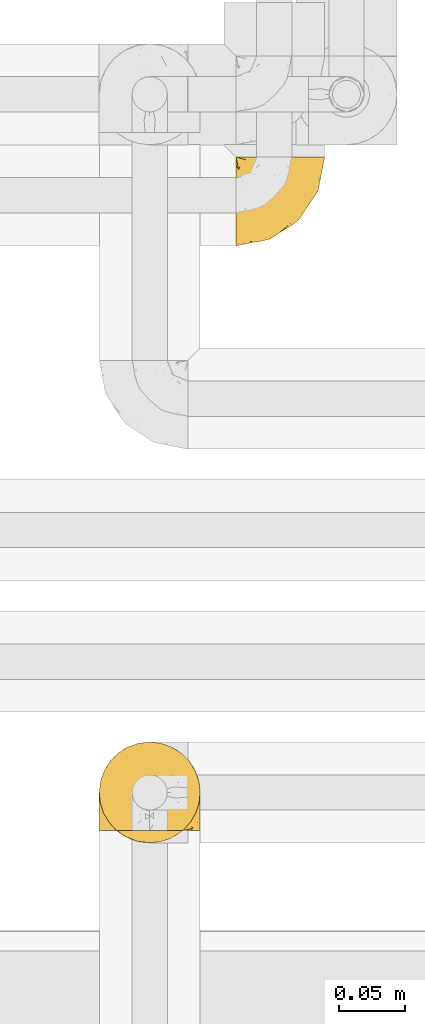
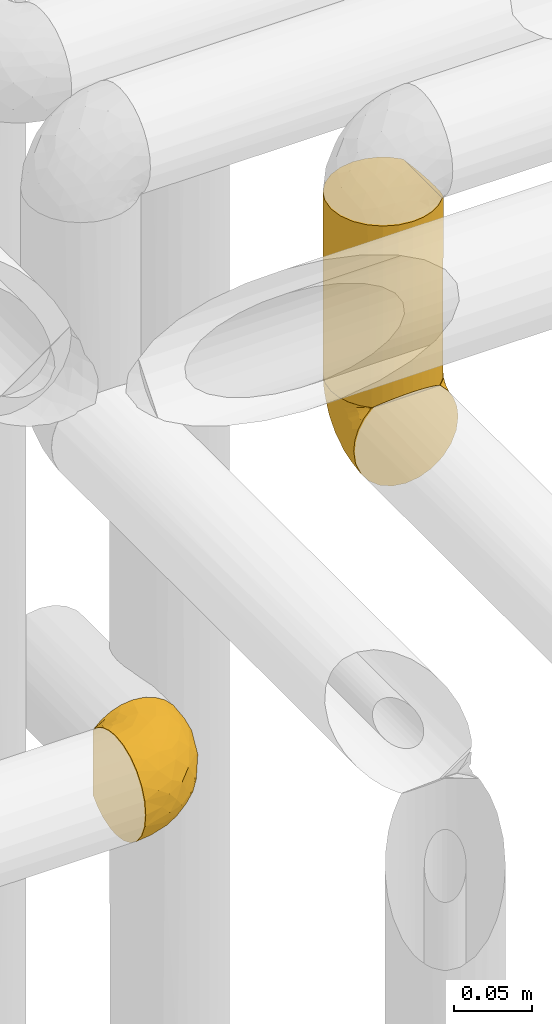
# One storey, part 290 of 827: 3 coverings.
"""IFC2X3 building model written with IfcOpenShell, lengths in millimetres."""

import ifcopenshell
import ifcopenshell.guid

model = None  # the IFC model being written
_history = None  # IfcOwnerHistory: only IFC2X3 demands one
_inside = {}  # id of a spatial element -> (the spatial element, [elements in it])
_under = {}  # id of a project, library or spatial element -> (it, [spatial elements below it])
_declared = {}  # id of a project -> (the project, [libraries it declares])
_typed = {}  # id of a type object -> (the type object, [elements of that type])
_made_of = {}  # id of a material, layer set ... -> (it, [elements and type objects made of it])


def new_model(schema):
    """Start an empty IFC model of exactly this schema.

    Asked for "IFC4X3", IfcOpenShell would pick the latest addendum, in which some entities
    have other attributes; the version numbers below select the first issue.
    IFC2X3 requires an IfcOwnerHistory on every rooted entity: one is made here for all.
    """
    global model, _history
    if schema == "IFC4X3":
        model = ifcopenshell.file(schema_version=(4, 3, 0, 0))
    else:
        model = ifcopenshell.file(schema=schema)
    _inside.clear()
    _under.clear()
    _declared.clear()
    _typed.clear()
    _made_of.clear()
    _history = None
    if model.schema == "IFC2X3":
        org = make("IfcOrganization", Name="unknown")
        user = make(
            "IfcPersonAndOrganization",
            ThePerson=make("IfcPerson", FamilyName="unknown"),
            TheOrganization=org,
        )
        app = make(
            "IfcApplication",
            ApplicationDeveloper=org,
            Version="unknown",
            ApplicationFullName="unknown",
            ApplicationIdentifier="unknown",
        )
        _history = make(
            "IfcOwnerHistory",
            OwningUser=user,
            OwningApplication=app,
            ChangeAction="ADDED",
            CreationDate=0,
        )
    return model


def make(cls, **values):
    """One entity of the class cls with the attributes given. An attribute that is None is left unset."""
    return model.create_entity(
        cls, **{name: value for name, value in values.items() if value is not None}
    )


def entity(cls, *values):
    """Any entity or typed value of the class cls, its attributes in the order of the schema. None: left unset."""
    e = model.create_entity(cls)
    for i, value in enumerate(values):
        if value is not None:
            e[i] = value
    return e


def rooted(cls, **values):
    """An entity with a GlobalId (a new one), such as an element, a storey or a relation."""
    return make(cls, GlobalId=ifcopenshell.guid.new(), OwnerHistory=_history, **values)


def si_unit(unit_type, name, prefix=None):
    """IfcSIUnit, for example si_unit("LENGTHUNIT", "METRE", prefix="MILLI")."""
    return make("IfcSIUnit", UnitType=unit_type, Prefix=prefix, Name=name)


def converted_unit(unit_type, name, factor, base, dimensions=None, offset=None):
    """IfcConversionBasedUnit, such as the inch: factor (a typed value) times the base unit."""
    return make(
        "IfcConversionBasedUnit"
        if offset is None
        else "IfcConversionBasedUnitWithOffset",
        ConversionOffset=offset,
        Dimensions=None
        if dimensions is None
        else entity("IfcDimensionalExponents", *dimensions),
        UnitType=unit_type,
        Name=name,
        ConversionFactor=make(
            "IfcMeasureWithUnit", ValueComponent=factor, UnitComponent=base
        ),
    )


def derived_unit(unit_type, elements):
    """IfcDerivedUnit: a product of units, each with its exponent."""
    return make(
        "IfcDerivedUnit",
        Elements=[
            make("IfcDerivedUnitElement", Unit=unit, Exponent=power)
            for unit, power in elements
        ],
        UnitType=unit_type,
    )


def assignment(units):
    """IfcUnitAssignment: the units of a project."""
    return None if units is None else make("IfcUnitAssignment", Units=units)


def point(xyz):
    """IfcCartesianPoint."""
    return None if xyz is None else make("IfcCartesianPoint", Coordinates=xyz)


def direction(xyz):
    """IfcDirection."""
    return None if xyz is None else make("IfcDirection", DirectionRatios=xyz)


def frame(location, z_axis=None, x_axis=None):
    """IfcAxis2Placement3D, a coordinate frame: its origin and axes. An axis left out is left unset."""
    return make(
        "IfcAxis2Placement3D",
        Location=point(location),
        Axis=direction(z_axis),
        RefDirection=direction(x_axis),
    )


def origin():
    """The frame at (0, 0, 0) with its axes left unset."""
    return frame((0.0, 0.0, 0.0))


def place(relative_to, where):
    """IfcLocalPlacement: puts the frame where relative to a parent placement (None: the world)."""
    return make(
        "IfcLocalPlacement", PlacementRelTo=relative_to, RelativePlacement=where
    )


def context(
    kind, dimensions, precision=None, world=None, true_north=None, identifier=None
):
    """IfcGeometricRepresentationContext, for example the 3D "Model" context."""
    return make(
        "IfcGeometricRepresentationContext",
        ContextIdentifier=identifier,
        ContextType=kind,
        CoordinateSpaceDimension=dimensions,
        Precision=precision,
        WorldCoordinateSystem=world,
        TrueNorth=true_north,
    )


def subcontext(parent, identifier, kind, view, scale=None):
    """IfcGeometricRepresentationSubContext, for example "Body" below "Model"."""
    return make(
        "IfcGeometricRepresentationSubContext",
        ContextIdentifier=identifier,
        ContextType=kind,
        ParentContext=parent,
        TargetScale=scale,
        TargetView=view,
    )


def project(units=None, contexts=None):
    """IfcProject with its units and contexts."""
    return rooted(
        "IfcProject",
        Name="project",
        RepresentationContexts=contexts,
        UnitsInContext=assignment(units),
    )


def spatial(cls, under=None, at=None, **own):
    """A site, building, storey or space (cls), placed at a placement, below another one or the project."""
    s = rooted(cls, ObjectPlacement=at, **own)
    if under is not None:
        _under.setdefault(under.id(), (under, []))[1].append(s)
    return s


def faces_of(points, faces, orient=None, outer=None):
    """IfcFace entities. A face is a list of loops; a loop is a list of indices into points, from 0.

    orient and outer hold one flag for each loop. By default every Orientation is true, the
    first loop of a face is its IfcFaceOuterBound and the others are IfcFaceBound.
    """
    made = []
    for i, loops in enumerate(faces):
        bounds = []
        for j, loop in enumerate(loops):
            is_outer = j == 0 if outer is None else outer[i][j]
            bounds.append(
                make(
                    "IfcFaceOuterBound" if is_outer else "IfcFaceBound",
                    Bound=make("IfcPolyLoop", Polygon=[points[k] for k in loop]),
                    Orientation=True if orient is None else orient[i][j],
                )
            )
        made.append(make("IfcFace", Bounds=bounds))
    return made


def faceted_brep(points, faces, orient=None, outer=None, voids=None):
    """IfcFacetedBrep: a solid bounded by flat faces; with voids (closed shells), ...WithVoids."""
    shared = [point(p) for p in points]
    hull = make("IfcClosedShell", CfsFaces=faces_of(shared, faces, orient, outer))
    if voids is None:
        return make("IfcFacetedBrep", Outer=hull)
    return make(
        "IfcFacetedBrepWithVoids",
        Outer=hull,
        Voids=[
            make(cls, CfsFaces=faces_of(shared, fs, o, b)) for cls, fs, o, b in voids
        ],
    )


def shape(context_of_items, identifier, shape_type, items):
    """IfcShapeRepresentation: the items that make up one representation, for example the "Body"."""
    return make(
        "IfcShapeRepresentation",
        ContextOfItems=context_of_items,
        RepresentationIdentifier=identifier,
        RepresentationType=shape_type,
        Items=items,
    )


def made_of(thing, what):
    """Note that an element or type object is made of a material, layer set ...; save() writes the relation."""
    if what is not None:
        _made_of.setdefault(what.id(), (what, []))[1].append(thing)
    return thing


def element(
    cls,
    number,
    at=None,
    inside=None,
    cuts=None,
    type_object=None,
    material=None,
    context=None,
    identifier="Body",
    shape_type=None,
    held_by="IfcProductDefinitionShape",
    body=None,
    shapes=None,
    **own,
):
    """One element of the class cls, such as IfcWall. Its Tag is "e" and its number.

    at: its placement. inside: the storey or other place that contains it. cuts: it is an
    opening in that element (IfcRelVoidsElement). A single representation is given by context,
    identifier, shape_type and body (its items); several are given by shapes. held_by: the class
    of the entity that holds the representations. save() writes the other relations.
    """
    e = rooted(cls, Tag="e%d" % number, ObjectPlacement=at, **own)
    if body is not None:
        shapes = [shape(context, identifier, shape_type, body)]
    if shapes is not None:
        e.Representation = make(held_by, Representations=shapes)
    if inside is not None:
        _inside.setdefault(inside.id(), (inside, []))[1].append(e)
    if cuts is not None:
        rooted(
            "IfcRelVoidsElement", RelatingBuildingElement=cuts, RelatedOpeningElement=e
        )
    if type_object is not None:
        _typed.setdefault(type_object.id(), (type_object, []))[1].append(e)
    return made_of(e, material)


def aggregate(whole, parts):
    """IfcRelAggregates: a whole, such as a stair, and the parts it consists of."""
    return rooted("IfcRelAggregates", RelatingObject=whole, RelatedObjects=parts)


def save(model, path):
    """Write the relations noted so far, then the file.

    IfcRelAggregates (storeys below a building ...), IfcRelContainedInSpatialStructure (elements
    in a storey), IfcRelDefinesByType, IfcRelAssociatesMaterial and IfcRelDeclares: one each for
    every whole, place, type object, material and project.
    """
    for whole, parts in _under.values():
        aggregate(whole, parts)
    for where, things in _inside.values():
        rooted(
            "IfcRelContainedInSpatialStructure",
            RelatedElements=things,
            RelatingStructure=where,
        )
    for kind, things in _typed.values():
        rooted("IfcRelDefinesByType", RelatedObjects=things, RelatingType=kind)
    for what, things in _made_of.values():
        rooted("IfcRelAssociatesMaterial", RelatedObjects=things, RelatingMaterial=what)
    for by, libraries in _declared.values():
        rooted("IfcRelDeclares", RelatingContext=by, RelatedDefinitions=libraries)
    model.write(path)


model = new_model("IFC2X3")

# Units and contexts
model_context = context("Model", 3, precision=0.01, world=origin(), true_north=direction((6.12303176911189e-17, 1.0)))
body_context = subcontext(model_context, "Body", "Model", "MODEL_VIEW")
ifc_project = project(units=[si_unit("LENGTHUNIT", "METRE", prefix="MILLI"), si_unit("AREAUNIT", "SQUARE_METRE"), si_unit("VOLUMEUNIT", "CUBIC_METRE"), converted_unit("PLANEANGLEUNIT", "DEGREE", entity("IfcRatioMeasure", 0.0174532925199433), si_unit("PLANEANGLEUNIT", "RADIAN"), dimensions=[0, 0, 0, 0, 0, 0, 0]), si_unit("MASSUNIT", "GRAM", prefix="KILO"), derived_unit("MASSDENSITYUNIT", [(si_unit("MASSUNIT", "GRAM", prefix="KILO"), 1), (si_unit("LENGTHUNIT", "METRE"), -3)]), derived_unit("MOMENTOFINERTIAUNIT", [(si_unit("LENGTHUNIT", "METRE"), 4)]), si_unit("TIMEUNIT", "SECOND"), si_unit("FREQUENCYUNIT", "HERTZ"), si_unit("THERMODYNAMICTEMPERATUREUNIT", "DEGREE_CELSIUS"), derived_unit("THERMALTRANSMITTANCEUNIT", [(si_unit("MASSUNIT", "GRAM", prefix="KILO"), 1), (si_unit("THERMODYNAMICTEMPERATUREUNIT", "KELVIN"), -1), (si_unit("TIMEUNIT", "SECOND"), -3)]), derived_unit("VOLUMETRICFLOWRATEUNIT", [(si_unit("LENGTHUNIT", "METRE"), 3), (si_unit("TIMEUNIT", "SECOND"), -1)]), derived_unit("MASSFLOWRATEUNIT", [(si_unit("MASSUNIT", "GRAM", prefix="KILO"), 1), (si_unit("TIMEUNIT", "SECOND"), -1)]), derived_unit("ROTATIONALFREQUENCYUNIT", [(si_unit("TIMEUNIT", "SECOND"), -1)]), si_unit("ELECTRICCURRENTUNIT", "AMPERE"), si_unit("ELECTRICVOLTAGEUNIT", "VOLT"), si_unit("POWERUNIT", "WATT"), si_unit("FORCEUNIT", "NEWTON", prefix="KILO"), si_unit("ILLUMINANCEUNIT", "LUX"), si_unit("LUMINOUSFLUXUNIT", "LUMEN"), si_unit("LUMINOUSINTENSITYUNIT", "CANDELA"), derived_unit("USERDEFINED", [(si_unit("MASSUNIT", "GRAM", prefix="KILO"), -1), (si_unit("LENGTHUNIT", "METRE"), -2), (si_unit("TIMEUNIT", "SECOND"), 3), (si_unit("LUMINOUSFLUXUNIT", "LUMEN"), 1)]), derived_unit("LINEARVELOCITYUNIT", [(si_unit("LENGTHUNIT", "METRE"), 1), (si_unit("TIMEUNIT", "SECOND"), -1)]), si_unit("PRESSUREUNIT", "PASCAL"), derived_unit("USERDEFINED", [(si_unit("LENGTHUNIT", "METRE"), -2), (si_unit("MASSUNIT", "GRAM", prefix="KILO"), 1), (si_unit("TIMEUNIT", "SECOND"), -2)]), derived_unit("LINEARFORCEUNIT", [(si_unit("MASSUNIT", "GRAM", prefix="KILO"), 1), (si_unit("LENGTHUNIT", "METRE"), 1), (si_unit("TIMEUNIT", "SECOND"), -2), (si_unit("LENGTHUNIT", "METRE"), -1)]), derived_unit("PLANARFORCEUNIT", [(si_unit("MASSUNIT", "GRAM", prefix="KILO"), 1), (si_unit("LENGTHUNIT", "METRE"), 1), (si_unit("TIMEUNIT", "SECOND"), -2), (si_unit("LENGTHUNIT", "METRE"), -2)])], contexts=[model_context])

# Site, building, storey
site_placement = place(None, origin())
site = spatial("IfcSite", under=ifc_project, at=site_placement, CompositionType="ELEMENT")
building_placement = place(site_placement, origin())
building = spatial("IfcBuilding", under=site, at=building_placement, CompositionType="ELEMENT")
storey_placement = place(building_placement, frame((0.0, 0.0, 28200.0)))
storey = spatial("IfcBuildingStorey", under=building, at=storey_placement, Name="08", CompositionType="ELEMENT", Elevation=28200.0)

# Coverings
covering_1_placement = place(storey_placement, frame((35057.15, 15705.01, 2169.95)))
element("IfcCovering", 1, at=covering_1_placement, inside=storey, Name=":ADSK_", ObjectType=":ADSK_", PredefinedType="INSULATION", context=body_context, shape_type="Brep", body=[
    faceted_brep([(47.38, 69.15, 74.68), (54.67, 69.15, 70.1), (60.76, 69.15, 64.01), (65.34, 69.15, 56.72), (68.18, 69.15, 48.6), (69.15, 69.15, 40.05), (68.18, 69.15, 31.49), (65.33, 69.15, 23.36), (60.75, 69.15, 16.07), (54.66, 69.15, 9.98), (47.37, 69.15, 5.4), (39.25, 69.15, 2.56), (30.7, 69.15, 1.6), (22.59, 69.15, 2.46), (14.86, 69.15, 5.01), (7.84, 69.15, 9.13), (1.85, 69.15, 14.62), (1.85, 69.15, 16.82), (1.85, 69.15, 18.56), (1.85, 69.15, 20.52), (1.85, 69.15, 22.49), (1.85, 69.15, 24.46), (1.85, 69.15, 26.42), (1.85, 69.15, 28.39), (1.85, 69.15, 30.36), (1.85, 69.15, 32.55), (1.85, 69.15, 34.75), (1.85, 69.15, 36.94), (1.85, 69.15, 39.13), (1.85, 69.15, 41.33), (1.85, 69.15, 43.52), (1.85, 69.15, 45.72), (1.85, 69.15, 47.91), (1.85, 69.15, 50.11), (1.85, 69.15, 52.3), (1.85, 69.15, 54.49), (1.85, 69.15, 56.69), (1.85, 69.15, 58.88), (1.85, 69.15, 61.08), (1.85, 69.15, 63.27), (1.85, 69.15, 65.47), (7.85, 69.15, 70.97), (14.88, 69.15, 75.09), (22.61, 69.15, 77.64), (30.7, 69.15, 78.5), (39.26, 69.15, 77.53), (1.6, 68.89, 14.62), (1.6, 62.89, 9.12), (1.6, 55.87, 5.0), (1.6, 48.14, 2.46), (1.6, 40.05, 1.6), (1.6, 30.09, 2.91), (1.6, 20.82, 6.75), (1.6, 12.86, 12.86), (1.6, 6.75, 20.82), (1.6, 2.91, 30.09), (1.6, 1.6, 40.05), (1.6, 2.91, 50.0), (1.6, 6.75, 59.27), (1.6, 12.86, 67.23), (1.6, 20.82, 73.34), (1.6, 30.09, 77.19), (1.6, 40.05, 78.5), (1.6, 48.14, 77.63), (1.6, 55.87, 75.09), (1.6, 62.89, 70.97), (1.6, 68.89, 65.47), (1.6, 68.89, 63.27), (1.6, 68.89, 62.29), (1.6, 68.89, 60.7), (1.6, 68.89, 59.11), (1.6, 68.89, 57.52), (1.6, 68.89, 55.93), (1.6, 68.89, 54.34), (1.6, 68.89, 52.76), (1.6, 68.89, 51.17), (1.6, 68.89, 49.58), (1.6, 68.89, 47.99), (1.6, 68.89, 46.4), (1.6, 68.89, 44.81), (1.6, 68.89, 43.22), (1.6, 68.89, 41.63), (1.6, 68.89, 40.05), (1.6, 68.89, 38.46), (1.6, 68.89, 36.87), (1.6, 68.89, 35.28), (1.6, 68.89, 33.69), (1.6, 68.89, 32.1), (1.6, 68.89, 30.51), (1.6, 68.89, 28.92), (1.6, 68.89, 27.33), (1.6, 68.89, 25.37), (1.6, 68.89, 23.4), (1.6, 68.89, 21.21), (1.6, 68.89, 19.01), (1.6, 68.89, 16.82), (1.78, 68.97, 42.32), (1.77, 68.96, 44.02), (1.78, 68.97, 47.13), (1.77, 68.97, 48.74), (1.79, 68.98, 23.57), (1.78, 68.97, 25.13), (1.76, 68.96, 61.34), (1.77, 68.96, 22.02), (1.77, 68.96, 29.72), (1.76, 68.96, 56.73), (1.77, 68.96, 55.14), (1.77, 68.96, 37.66), (1.8, 69.0, 64.12), (1.76, 68.96, 28.13), (1.77, 68.96, 26.62), (1.78, 68.97, 31.46), (1.77, 68.96, 16.16), (1.77, 68.96, 39.16), (1.76, 68.96, 50.37), (1.77, 68.97, 17.69), (1.78, 68.97, 19.17), (1.77, 68.97, 62.78), (1.77, 68.96, 58.35), (1.77, 68.96, 45.53), (1.78, 68.97, 59.91), (1.77, 68.97, 65.47), (1.8, 69.02, 65.47), (1.82, 69.08, 65.47), (1.77, 68.97, 14.62), (1.72, 68.94, 14.62), (1.66, 68.92, 14.62), (1.76, 68.96, 20.59), (1.77, 68.96, 32.99), (1.76, 68.95, 34.48), (1.77, 68.96, 51.91), (1.66, 68.92, 65.47), (1.72, 68.94, 65.47), (1.78, 68.98, 53.48), (1.82, 69.08, 14.62), (1.8, 69.02, 14.62), (1.77, 68.96, 40.77), (1.78, 68.97, 35.97), (3.72, 61.33, 7.84), (7.41, 53.1, 3.53), (6.13, 63.33, 8.32), (21.47, 49.27, 1.6), (19.34, 55.53, 2.19), (26.8, 54.6, 1.6), (8.87, 41.99, 1.6), (9.2, 57.07, 4.57), (12.79, 57.95, 3.96), (14.62, 51.56, 2.28), (7.34, 41.58, 1.6), (5.33, 61.7, 7.69), (17.64, 63.33, 3.53), (7.7, 65.0, 8.32), (9.41, 67.02, 7.84), (28.75, 61.87, 1.6), (16.15, 43.94, 1.6), (14.14, 61.21, 4.34), (29.16, 63.4, 1.6), (57.02, 33.11, 29.63), (64.92, 52.82, 27.34), (64.0, 43.3, 40.05), (11.92, 33.73, 2.39), (19.16, 36.52, 2.43), (28.65, 24.87, 9.07), (24.62, 14.17, 16.64), (15.19, 18.43, 9.54), (18.36, 28.67, 4.52), (9.2, 26.0, 4.52), (46.98, 49.25, 7.49), (50.24, 59.72, 7.49), (56.1, 55.1, 12.85), (28.97, 44.72, 2.35), (54.46, 34.15, 22.66), (21.34, 5.25, 32.9), (18.4, 6.75, 25.33), (66.44, 55.54, 40.05), (12.07, 10.47, 16.64), (45.49, 25.49, 19.99), (50.57, 35.53, 16.37), (36.04, 48.22, 3.26), (42.07, 58.71, 3.75), (62.12, 57.42, 19.58), (37.37, 34.84, 7.5), (29.39, 36.87, 4.04), (53.59, 45.01, 13.94), (58.06, 44.4, 19.58), (49.27, 23.96, 28.21), (29.63, 11.2, 24.75), (33.21, 10.56, 31.42), (40.1, 16.81, 26.2), (44.08, 17.38, 33.36), (49.36, 21.38, 40.05), (56.68, 32.34, 40.05), (15.2, 4.3, 40.05), (35.57, 20.65, 16.14), (41.7, 29.66, 12.85), (46.4, 39.6, 10.47), (41.41, 42.55, 6.49), (27.45, 6.74, 40.05), (38.4, 14.06, 40.05), (12.99, 26.84, 75.57), (21.33, 5.28, 47.37), (42.89, 18.52, 52.91), (57.04, 33.13, 50.46), (56.11, 55.1, 67.23), (62.13, 57.43, 60.5), (21.89, 20.72, 70.55), (16.62, 11.46, 63.45), (32.9, 17.69, 62.61), (46.99, 49.26, 72.6), (50.25, 59.73, 72.6), (42.08, 58.71, 76.34), (49.91, 29.72, 59.34), (15.6, 35.35, 77.76), (16.15, 43.94, 78.5), (8.87, 41.99, 78.5), (29.16, 63.4, 78.5), (13.16, 4.93, 53.16), (10.83, 17.46, 70.55), (33.8, 10.94, 48.88), (25.02, 8.92, 54.76), (64.92, 52.83, 52.74), (32.83, 29.34, 71.93), (20.56, 30.26, 75.79), (58.07, 44.4, 60.5), (21.46, 39.06, 77.86), (28.1, 43.06, 77.64), (26.8, 54.6, 78.5), (21.47, 49.27, 78.5), (51.29, 42.69, 67.23), (36.04, 48.2, 76.82), (28.75, 61.87, 78.5), (8.45, 33.44, 77.8), (41.73, 29.67, 67.23), (39.27, 38.5, 73.2), (33.56, 23.35, 67.66), (27.29, 34.97, 75.99), (7.41, 53.1, 76.57), (3.51, 59.68, 73.21), (4.68, 62.19, 71.93), (5.52, 64.11, 71.07), (8.75, 57.97, 75.09), (12.79, 57.95, 76.13), (17.65, 63.33, 76.57), (13.9, 51.77, 77.69), (9.42, 67.02, 72.26), (7.68, 64.98, 71.77), (19.33, 55.53, 77.9), (14.13, 61.22, 75.75)], [[[0, 1, 2, 3, 4, 5, 6, 7, 8, 9, 10, 11, 12, 13, 14, 15, 16, 17, 18, 19, 20, 21, 22, 23, 24, 25, 26, 27, 28, 29, 30, 31, 32, 33, 34, 35, 36, 37, 38, 39, 40, 41, 42, 43, 44, 45]], [[46, 47, 48, 49, 50, 51, 52, 53, 54, 55, 56, 57, 58, 59, 60, 61, 62, 63, 64, 65, 66, 67, 68, 69, 70, 71, 72, 73, 74, 75, 76, 77, 78, 79, 80, 81, 82, 83, 84, 85, 86, 87, 88, 89, 90, 91, 92, 93, 94, 95]], [[96, 97, 30]], [[98, 77, 99]], [[100, 101, 21]], [[69, 68, 102]], [[20, 19, 103]], [[24, 23, 104]], [[20, 103, 100]], [[72, 105, 106]], [[84, 83, 107]], [[89, 88, 104]], [[108, 67, 66]], [[109, 110, 90]], [[111, 25, 24]], [[112, 17, 16]], [[82, 113, 83]], [[109, 23, 22]], [[114, 76, 75]], [[105, 36, 106]], [[104, 111, 24]], [[18, 115, 116]], [[97, 96, 80]], [[67, 108, 117]], [[105, 71, 118]], [[31, 97, 119]], [[102, 120, 69]], [[108, 121, 122, 123, 40]], [[112, 95, 115]], [[17, 115, 18]], [[94, 116, 115]], [[117, 68, 67]], [[38, 117, 39]], [[112, 124, 125]], [[112, 126, 46]], [[17, 112, 115]], [[70, 120, 118]], [[39, 117, 108]], [[120, 38, 37]], [[120, 37, 118]], [[120, 70, 69]], [[116, 94, 127]], [[128, 86, 129]], [[117, 38, 102]], [[74, 130, 75]], [[99, 33, 32]], [[115, 95, 94]], [[39, 108, 40]], [[108, 66, 131, 132, 121]], [[105, 72, 71]], [[118, 37, 36]], [[71, 70, 118]], [[35, 106, 36]], [[36, 105, 118]], [[35, 133, 106]], [[74, 73, 133]], [[106, 133, 73]], [[99, 114, 33]], [[133, 35, 34]], [[73, 72, 106]], [[95, 112, 46]], [[112, 16, 134, 135, 124]], [[130, 114, 75]], [[99, 76, 114]], [[114, 130, 33]], [[34, 33, 130]], [[78, 77, 98]], [[98, 119, 78]], [[130, 133, 34]], [[133, 130, 74]], [[79, 97, 80]], [[98, 99, 32]], [[98, 32, 31]], [[77, 76, 99]], [[97, 79, 119]], [[136, 96, 29]], [[30, 97, 31]], [[136, 29, 28]], [[81, 80, 96]], [[29, 96, 30]], [[31, 119, 98]], [[119, 79, 78]], [[96, 136, 81]], [[82, 81, 136]], [[113, 107, 83]], [[84, 107, 137]], [[107, 27, 137]], [[113, 28, 107]], [[27, 107, 28]], [[85, 84, 137]], [[137, 27, 26]], [[113, 136, 28]], [[136, 113, 82]], [[109, 89, 104]], [[86, 85, 129]], [[89, 109, 90]], [[111, 87, 128]], [[26, 129, 137]], [[88, 111, 104]], [[25, 111, 128]], [[22, 110, 109]], [[23, 109, 104]], [[110, 91, 90]], [[100, 92, 101]], [[110, 22, 101]], [[91, 110, 101]], [[116, 19, 18]], [[111, 88, 87]], [[127, 103, 19]], [[25, 128, 26]], [[86, 128, 87]], [[128, 129, 26]], [[137, 129, 85]], [[120, 102, 38]], [[117, 102, 68]], [[91, 101, 92]], [[21, 101, 22]], [[93, 92, 103]], [[100, 21, 20]], [[100, 103, 92]], [[127, 93, 103]], [[93, 127, 94]], [[116, 127, 19]], [[126, 138, 47]], [[48, 138, 139]], [[140, 125, 124]], [[141, 142, 143]], [[144, 49, 139]], [[145, 140, 146]], [[48, 139, 49]], [[139, 145, 147]], [[49, 144, 148, 50]], [[126, 125, 149]], [[14, 13, 150]], [[151, 146, 140]], [[149, 140, 145]], [[152, 151, 135]], [[152, 14, 150]], [[16, 15, 134]], [[13, 153, 150]], [[124, 151, 140]], [[141, 147, 142]], [[14, 152, 15]], [[15, 152, 134]], [[47, 46, 126]], [[139, 154, 144]], [[138, 48, 47]], [[125, 140, 149]], [[135, 134, 152]], [[146, 155, 142]], [[145, 146, 147]], [[149, 139, 138]], [[147, 141, 154]], [[147, 146, 142]], [[139, 147, 154]], [[139, 149, 145]], [[149, 138, 126]], [[155, 146, 151]], [[150, 143, 142]], [[152, 155, 151]], [[150, 142, 155]], [[13, 12, 156, 153]], [[153, 143, 150]], [[152, 150, 155]], [[151, 124, 135]], [[157, 158, 159]], [[160, 154, 161]], [[162, 163, 164]], [[165, 166, 160]], [[167, 168, 169]], [[141, 170, 161]], [[156, 12, 11]], [[158, 157, 171]], [[172, 55, 173]], [[158, 6, 174]], [[175, 54, 53]], [[52, 166, 164]], [[52, 164, 53]], [[54, 175, 173]], [[166, 52, 51]], [[176, 177, 171]], [[178, 143, 179]], [[156, 11, 179]], [[8, 7, 180]], [[169, 9, 8]], [[179, 143, 153, 156]], [[179, 11, 10]], [[168, 179, 10]], [[181, 162, 182]], [[179, 167, 178]], [[183, 184, 177]], [[183, 169, 184]], [[176, 171, 185]], [[172, 186, 187]], [[158, 7, 6]], [[159, 158, 174]], [[184, 180, 158]], [[54, 173, 55]], [[180, 169, 8]], [[188, 189, 187]], [[9, 168, 10]], [[186, 188, 187]], [[190, 157, 159, 191]], [[55, 172, 192]], [[176, 193, 194]], [[161, 170, 182]], [[162, 164, 165]], [[175, 164, 163]], [[51, 50, 148]], [[167, 195, 196]], [[178, 182, 170]], [[6, 5, 174]], [[158, 180, 7]], [[169, 180, 184]], [[169, 168, 9]], [[179, 168, 167]], [[182, 162, 165]], [[162, 194, 193]], [[161, 165, 160]], [[195, 181, 196]], [[192, 172, 197]], [[192, 56, 55]], [[189, 190, 198]], [[198, 197, 187]], [[172, 187, 197]], [[185, 189, 188]], [[198, 187, 189]], [[186, 172, 173]], [[173, 163, 186]], [[193, 186, 163]], [[176, 185, 188]], [[185, 157, 190]], [[188, 186, 193]], [[177, 176, 194]], [[188, 193, 176]], [[162, 193, 163]], [[195, 177, 194]], [[171, 177, 184]], [[181, 195, 194]], [[183, 167, 169]], [[162, 181, 194]], [[196, 182, 178]], [[158, 171, 184]], [[171, 157, 185]], [[177, 195, 183]], [[167, 183, 195]], [[182, 196, 181]], [[178, 170, 143]], [[178, 167, 196]], [[164, 175, 53]], [[173, 175, 163]], [[160, 51, 148]], [[164, 166, 165]], [[51, 160, 166]], [[160, 148, 144, 154]], [[141, 161, 154]], [[182, 165, 161]], [[190, 189, 185]], [[143, 170, 141]], [[60, 199, 61]], [[197, 200, 192]], [[201, 190, 202]], [[200, 57, 192]], [[203, 204, 2]], [[205, 206, 207]], [[208, 209, 210]], [[211, 207, 201]], [[212, 213, 214]], [[45, 215, 210]], [[216, 206, 58]], [[45, 44, 215]], [[59, 217, 60]], [[60, 217, 199]], [[0, 45, 210]], [[218, 201, 219]], [[202, 159, 220]], [[205, 221, 222]], [[223, 204, 203]], [[1, 203, 2]], [[57, 200, 216]], [[220, 3, 204]], [[220, 174, 4]], [[1, 0, 209]], [[212, 224, 213]], [[225, 226, 227]], [[228, 223, 203]], [[208, 210, 229]], [[210, 226, 229]], [[3, 220, 4]], [[58, 206, 59]], [[209, 203, 1]], [[202, 220, 223]], [[228, 203, 208]], [[202, 211, 201]], [[3, 2, 204]], [[202, 190, 191, 159]], [[210, 215, 230, 226]], [[199, 212, 231]], [[232, 233, 221]], [[233, 208, 229]], [[207, 206, 219]], [[217, 206, 205]], [[227, 224, 225]], [[233, 232, 228]], [[201, 207, 219]], [[234, 232, 221]], [[218, 219, 200]], [[202, 223, 211]], [[174, 220, 159]], [[174, 5, 4]], [[61, 231, 62]], [[220, 204, 223]], [[210, 209, 0]], [[203, 209, 208]], [[225, 233, 229]], [[224, 227, 213]], [[221, 233, 235]], [[57, 56, 192]], [[198, 218, 197]], [[200, 219, 216]], [[201, 198, 190]], [[197, 218, 200]], [[198, 201, 218]], [[206, 216, 219]], [[58, 57, 216]], [[231, 212, 214]], [[222, 212, 199]], [[228, 211, 223]], [[207, 211, 232]], [[62, 231, 214]], [[199, 231, 61]], [[233, 228, 208]], [[211, 228, 232]], [[222, 221, 235]], [[234, 205, 207]], [[206, 217, 59]], [[199, 217, 205]], [[205, 222, 199]], [[224, 222, 235]], [[222, 224, 212]], [[224, 235, 225]], [[233, 225, 235]], [[226, 225, 229]], [[205, 234, 221]], [[207, 232, 234]], [[63, 214, 236]], [[214, 213, 236]], [[214, 63, 62]], [[237, 236, 238]], [[238, 132, 131]], [[236, 237, 64]], [[239, 240, 241]], [[63, 236, 64]], [[131, 66, 65]], [[237, 131, 65]], [[242, 230, 43]], [[237, 65, 64]], [[239, 121, 132]], [[42, 242, 43]], [[241, 240, 243]], [[41, 123, 244]], [[43, 230, 215, 44]], [[244, 122, 245]], [[227, 246, 243]], [[241, 247, 245]], [[121, 239, 245]], [[41, 40, 123]], [[132, 238, 239]], [[244, 42, 41]], [[131, 237, 238]], [[240, 239, 238]], [[245, 239, 241]], [[247, 241, 246]], [[247, 244, 245]], [[238, 236, 240]], [[243, 236, 213]], [[236, 243, 240]], [[227, 226, 246]], [[243, 213, 227]], [[242, 246, 226]], [[243, 246, 241]], [[246, 242, 247]], [[244, 247, 242]], [[242, 226, 230]], [[42, 244, 242]], [[122, 244, 123]], [[122, 121, 245]], [[112, 125, 126]]]),
])
covering_2_placement = place(storey_placement, frame((34952.89, 15250.0, 2827.5)))
element("IfcCovering", 2, at=covering_2_placement, inside=storey, Name=":ADSK_", ObjectType=":ADSK_", PredefinedType="INSULATION", context=body_context, shape_type="Brep", body=[
    faceted_brep([(2.48, 31.79, 1.6), (1.6, 40.0, 1.6), (2.9, 49.93, 1.6), (6.74, 59.2, 1.6), (12.84, 67.15, 1.6), (20.8, 73.25, 1.6), (30.06, 77.09, 1.6), (40.0, 78.4, 1.6), (49.93, 77.09, 1.6), (59.2, 73.25, 1.6), (67.15, 67.15, 1.6), (73.25, 59.2, 1.6), (77.09, 49.93, 1.6), (78.4, 40.0, 1.6), (77.51, 31.79, 1.6), (74.9, 23.98, 1.6), (70.68, 16.91, 1.6), (65.05, 10.9, 1.6), (14.94, 10.9, 1.6), (9.31, 16.91, 1.6), (5.09, 23.98, 1.6), (1.6, 40.0, 143.4), (2.9, 30.06, 143.4), (6.74, 20.8, 143.4), (12.84, 12.84, 143.4), (20.8, 6.74, 143.4), (30.06, 2.9, 143.4), (40.0, 1.6, 143.4), (48.2, 2.48, 143.4), (56.01, 5.09, 143.4), (63.08, 9.31, 143.4), (69.1, 14.94, 143.4), (69.1, 65.05, 143.4), (63.08, 70.68, 143.4), (56.01, 74.9, 143.4), (48.2, 77.51, 143.4), (40.0, 78.4, 143.4), (30.06, 77.09, 143.4), (20.8, 73.25, 143.4), (12.84, 67.15, 143.4), (6.74, 59.2, 143.4), (2.9, 49.93, 143.4), (73.07, 59.51, 139.42), (76.0, 53.36, 136.5), (77.79, 46.78, 134.7), (78.4, 40.0, 134.1), (77.79, 33.21, 134.7), (76.0, 26.63, 136.5), (73.07, 20.48, 139.42), (59.51, 6.92, 5.57), (53.36, 4.0, 8.5), (46.78, 2.2, 10.29), (40.0, 1.6, 10.9), (33.21, 2.2, 10.29), (26.63, 4.0, 8.5), (20.48, 6.92, 5.57)], [[[0, 1, 2, 3, 4, 5, 6, 7, 8, 9, 10, 11, 12, 13, 14, 15, 16, 17, 18, 19, 20]], [[21, 22, 23, 24, 25, 26, 27, 28, 29, 30, 31, 32, 33, 34, 35, 36, 37, 38, 39, 40, 41]], [[36, 35, 7]], [[34, 33, 9]], [[35, 34, 8]], [[8, 7, 35]], [[9, 8, 34]], [[33, 10, 9]], [[33, 32, 10]], [[32, 42, 11]], [[43, 44, 12]], [[42, 43, 11]], [[11, 43, 12]], [[13, 12, 44]], [[45, 13, 44]], [[32, 11, 10]], [[46, 47, 14]], [[48, 31, 16]], [[47, 48, 15]], [[45, 46, 13]], [[14, 13, 46]], [[47, 15, 14]], [[48, 16, 15]], [[31, 17, 16]], [[49, 30, 29]], [[50, 29, 28]], [[51, 28, 27]], [[49, 17, 30]], [[51, 50, 28]], [[52, 51, 27]], [[49, 29, 50]], [[30, 17, 31]], [[53, 52, 27]], [[53, 27, 26]], [[54, 26, 25]], [[54, 53, 26]], [[18, 55, 25]], [[54, 25, 55]], [[25, 24, 18]], [[19, 24, 23]], [[20, 23, 22]], [[0, 22, 21]], [[19, 23, 20]], [[20, 22, 0]], [[21, 1, 0]], [[24, 19, 18]], [[2, 1, 21, 41]], [[3, 2, 41, 40]], [[40, 39, 4, 3]], [[6, 5, 38, 37]], [[7, 6, 37, 36]], [[39, 38, 5, 4]], [[49, 50, 51, 52, 53, 54, 55, 18, 17]], [[31, 48, 47, 46, 45, 44, 43, 42, 32]]]),
])
covering_3_placement = place(storey_placement, frame((34952.84, 15259.3, 2759.95)))
element("IfcCovering", 3, at=covering_3_placement, inside=storey, Name=":ADSK_", ObjectType=":ADSK_", PredefinedType="INSULATION", context=body_context, shape_type="Brep", body=[
    faceted_brep([(74.68, 47.38, 69.15), (70.1, 54.67, 69.15), (64.01, 60.76, 69.15), (56.72, 65.34, 69.15), (48.6, 68.18, 69.15), (40.05, 69.15, 69.15), (31.49, 68.18, 69.15), (23.36, 65.33, 69.15), (16.07, 60.75, 69.15), (9.98, 54.66, 69.15), (5.4, 47.37, 69.15), (2.56, 39.25, 69.15), (1.6, 30.7, 69.15), (2.46, 22.59, 69.15), (5.01, 14.86, 69.15), (9.13, 7.84, 69.15), (14.62, 1.85, 69.15), (16.82, 1.85, 69.15), (18.56, 1.85, 69.15), (20.52, 1.85, 69.15), (22.49, 1.85, 69.15), (24.46, 1.85, 69.15), (26.42, 1.85, 69.15), (28.39, 1.85, 69.15), (30.36, 1.85, 69.15), (32.55, 1.85, 69.15), (34.75, 1.85, 69.15), (36.94, 1.85, 69.15), (39.13, 1.85, 69.15), (41.33, 1.85, 69.15), (43.52, 1.85, 69.15), (45.72, 1.85, 69.15), (47.91, 1.85, 69.15), (50.11, 1.85, 69.15), (52.3, 1.85, 69.15), (54.49, 1.85, 69.15), (56.69, 1.85, 69.15), (58.88, 1.85, 69.15), (61.08, 1.85, 69.15), (63.27, 1.85, 69.15), (65.47, 1.85, 69.15), (70.97, 7.85, 69.15), (75.09, 14.88, 69.15), (77.64, 22.61, 69.15), (78.5, 30.7, 69.15), (77.53, 39.26, 69.15), (14.62, 1.6, 68.89), (9.12, 1.6, 62.89), (5.0, 1.6, 55.87), (2.46, 1.6, 48.14), (1.6, 1.6, 40.05), (2.91, 1.6, 30.09), (6.75, 1.6, 20.82), (12.86, 1.6, 12.86), (20.82, 1.6, 6.75), (30.09, 1.6, 2.91), (40.05, 1.6, 1.6), (50.0, 1.6, 2.91), (59.27, 1.6, 6.75), (67.23, 1.6, 12.86), (73.34, 1.6, 20.82), (77.19, 1.6, 30.09), (78.5, 1.6, 40.05), (77.63, 1.6, 48.14), (75.09, 1.6, 55.87), (70.97, 1.6, 62.89), (65.47, 1.6, 68.89), (63.27, 1.6, 68.89), (62.29, 1.6, 68.89), (60.7, 1.6, 68.89), (59.11, 1.6, 68.89), (57.52, 1.6, 68.89), (55.93, 1.6, 68.89), (54.34, 1.6, 68.89), (52.76, 1.6, 68.89), (51.17, 1.6, 68.89), (49.58, 1.6, 68.89), (47.99, 1.6, 68.89), (46.4, 1.6, 68.89), (44.81, 1.6, 68.89), (43.22, 1.6, 68.89), (41.63, 1.6, 68.89), (40.05, 1.6, 68.89), (38.46, 1.6, 68.89), (36.87, 1.6, 68.89), (35.28, 1.6, 68.89), (33.69, 1.6, 68.89), (32.1, 1.6, 68.89), (30.51, 1.6, 68.89), (28.92, 1.6, 68.89), (27.33, 1.6, 68.89), (25.37, 1.6, 68.89), (23.4, 1.6, 68.89), (21.21, 1.6, 68.89), (19.01, 1.6, 68.89), (16.82, 1.6, 68.89), (42.32, 1.78, 68.97), (44.02, 1.77, 68.96), (47.13, 1.78, 68.97), (48.74, 1.77, 68.97), (23.57, 1.79, 68.98), (25.13, 1.78, 68.97), (61.34, 1.76, 68.96), (22.02, 1.77, 68.96), (29.72, 1.77, 68.96), (56.73, 1.76, 68.96), (55.14, 1.77, 68.96), (37.66, 1.77, 68.96), (64.12, 1.8, 69.0), (28.13, 1.76, 68.96), (26.62, 1.77, 68.96), (31.46, 1.78, 68.97), (16.16, 1.77, 68.96), (39.16, 1.77, 68.96), (50.37, 1.76, 68.96), (17.69, 1.77, 68.97), (19.17, 1.78, 68.97), (62.78, 1.77, 68.97), (58.35, 1.77, 68.96), (45.53, 1.77, 68.96), (59.91, 1.78, 68.97), (65.47, 1.77, 68.97), (65.47, 1.8, 69.02), (65.47, 1.82, 69.08), (14.62, 1.77, 68.97), (14.62, 1.72, 68.94), (14.62, 1.66, 68.92), (20.59, 1.76, 68.96), (32.99, 1.77, 68.96), (34.48, 1.76, 68.95), (51.91, 1.77, 68.96), (65.47, 1.66, 68.92), (65.47, 1.72, 68.94), (53.48, 1.78, 68.98), (14.62, 1.82, 69.08), (14.62, 1.8, 69.02), (40.77, 1.77, 68.96), (35.97, 1.78, 68.97), (7.84, 3.72, 61.33), (3.53, 7.41, 53.1), (8.32, 6.13, 63.33), (1.6, 21.47, 49.27), (2.19, 19.34, 55.53), (1.6, 26.8, 54.6), (1.6, 8.87, 41.99), (4.57, 9.2, 57.07), (3.96, 12.79, 57.95), (2.28, 14.62, 51.56), (1.6, 7.34, 41.58), (7.69, 5.33, 61.7), (3.53, 17.64, 63.33), (8.32, 7.7, 65.0), (7.84, 9.41, 67.02), (1.6, 28.75, 61.87), (1.6, 16.15, 43.94), (4.34, 14.14, 61.21), (1.6, 29.16, 63.4), (29.63, 57.02, 33.11), (27.34, 64.92, 52.82), (40.05, 64.0, 43.3), (2.39, 11.92, 33.73), (2.43, 19.16, 36.52), (9.07, 28.65, 24.87), (16.64, 24.62, 14.17), (9.54, 15.19, 18.43), (4.52, 18.36, 28.67), (4.52, 9.2, 26.0), (7.49, 46.98, 49.25), (7.49, 50.24, 59.72), (12.85, 56.1, 55.1), (2.35, 28.97, 44.72), (22.66, 54.46, 34.15), (32.9, 21.34, 5.25), (25.33, 18.4, 6.75), (40.05, 66.44, 55.54), (16.64, 12.07, 10.47), (19.99, 45.49, 25.49), (16.37, 50.57, 35.53), (3.26, 36.04, 48.22), (3.75, 42.07, 58.71), (19.58, 62.12, 57.42), (7.5, 37.37, 34.84), (4.04, 29.39, 36.87), (13.94, 53.59, 45.01), (19.58, 58.06, 44.4), (28.21, 49.27, 23.96), (24.75, 29.63, 11.2), (31.42, 33.21, 10.56), (26.2, 40.1, 16.81), (33.36, 44.08, 17.38), (40.05, 49.36, 21.38), (40.05, 56.68, 32.34), (40.05, 15.2, 4.3), (16.14, 35.57, 20.65), (12.85, 41.7, 29.66), (10.47, 46.4, 39.6), (6.49, 41.41, 42.55), (40.05, 27.45, 6.74), (40.05, 38.4, 14.06), (75.57, 12.99, 26.84), (47.37, 21.33, 5.28), (52.91, 42.89, 18.52), (50.46, 57.04, 33.13), (67.23, 56.11, 55.1), (60.5, 62.13, 57.43), (70.55, 21.89, 20.72), (63.45, 16.62, 11.46), (62.61, 32.9, 17.69), (72.6, 46.99, 49.26), (72.6, 50.25, 59.73), (76.34, 42.08, 58.71), (59.34, 49.91, 29.72), (77.76, 15.6, 35.35), (78.5, 16.15, 43.94), (78.5, 8.87, 41.99), (78.5, 29.16, 63.4), (53.16, 13.16, 4.93), (70.55, 10.83, 17.46), (48.88, 33.8, 10.94), (54.76, 25.02, 8.92), (52.74, 64.92, 52.83), (71.93, 32.83, 29.34), (75.79, 20.56, 30.26), (60.5, 58.07, 44.4), (77.86, 21.46, 39.06), (77.64, 28.1, 43.06), (78.5, 26.8, 54.6), (78.5, 21.47, 49.27), (67.23, 51.29, 42.69), (76.82, 36.04, 48.2), (78.5, 28.75, 61.87), (77.8, 8.45, 33.44), (67.23, 41.73, 29.67), (73.2, 39.27, 38.5), (67.66, 33.56, 23.35), (75.99, 27.29, 34.97), (76.57, 7.41, 53.1), (73.21, 3.51, 59.68), (71.93, 4.68, 62.19), (71.07, 5.52, 64.11), (75.09, 8.75, 57.97), (76.13, 12.79, 57.95), (76.57, 17.65, 63.33), (77.69, 13.9, 51.77), (72.26, 9.42, 67.02), (71.77, 7.68, 64.98), (77.9, 19.33, 55.53), (75.75, 14.13, 61.22)], [[[0, 1, 2, 3, 4, 5, 6, 7, 8, 9, 10, 11, 12, 13, 14, 15, 16, 17, 18, 19, 20, 21, 22, 23, 24, 25, 26, 27, 28, 29, 30, 31, 32, 33, 34, 35, 36, 37, 38, 39, 40, 41, 42, 43, 44, 45]], [[46, 47, 48, 49, 50, 51, 52, 53, 54, 55, 56, 57, 58, 59, 60, 61, 62, 63, 64, 65, 66, 67, 68, 69, 70, 71, 72, 73, 74, 75, 76, 77, 78, 79, 80, 81, 82, 83, 84, 85, 86, 87, 88, 89, 90, 91, 92, 93, 94, 95]], [[96, 97, 30]], [[98, 77, 99]], [[100, 101, 21]], [[69, 68, 102]], [[20, 19, 103]], [[24, 23, 104]], [[20, 103, 100]], [[72, 105, 106]], [[84, 83, 107]], [[89, 88, 104]], [[108, 67, 66]], [[109, 110, 90]], [[111, 25, 24]], [[112, 17, 16]], [[82, 113, 83]], [[109, 23, 22]], [[114, 76, 75]], [[105, 36, 106]], [[104, 111, 24]], [[18, 115, 116]], [[97, 96, 80]], [[67, 108, 117]], [[105, 71, 118]], [[31, 97, 119]], [[102, 120, 69]], [[108, 121, 122, 123, 40]], [[112, 95, 115]], [[17, 115, 18]], [[94, 116, 115]], [[117, 68, 67]], [[38, 117, 39]], [[112, 124, 125, 126, 46]], [[17, 112, 115]], [[70, 120, 118]], [[39, 117, 108]], [[120, 38, 37]], [[120, 37, 118]], [[120, 70, 69]], [[116, 94, 127]], [[128, 86, 129]], [[117, 38, 102]], [[74, 130, 75]], [[99, 33, 32]], [[115, 95, 94]], [[39, 108, 40]], [[108, 66, 131, 132, 121]], [[105, 72, 71]], [[118, 37, 36]], [[71, 70, 118]], [[35, 106, 36]], [[36, 105, 118]], [[35, 133, 106]], [[74, 73, 133]], [[106, 133, 73]], [[99, 114, 33]], [[133, 35, 34]], [[73, 72, 106]], [[95, 112, 46]], [[112, 16, 134, 135, 124]], [[130, 114, 75]], [[99, 76, 114]], [[114, 130, 33]], [[34, 33, 130]], [[78, 77, 98]], [[98, 119, 78]], [[130, 133, 34]], [[133, 130, 74]], [[79, 97, 80]], [[98, 99, 32]], [[98, 32, 31]], [[77, 76, 99]], [[97, 79, 119]], [[136, 96, 29]], [[30, 97, 31]], [[136, 29, 28]], [[81, 80, 96]], [[29, 96, 30]], [[31, 119, 98]], [[119, 79, 78]], [[96, 136, 81]], [[82, 81, 136]], [[113, 107, 83]], [[84, 107, 137]], [[107, 27, 137]], [[113, 28, 107]], [[27, 107, 28]], [[85, 84, 137]], [[137, 27, 26]], [[113, 136, 28]], [[136, 113, 82]], [[109, 89, 104]], [[86, 85, 129]], [[89, 109, 90]], [[111, 87, 128]], [[26, 129, 137]], [[88, 111, 104]], [[25, 111, 128]], [[22, 110, 109]], [[23, 109, 104]], [[110, 91, 90]], [[100, 92, 101]], [[110, 22, 101]], [[91, 110, 101]], [[116, 19, 18]], [[111, 88, 87]], [[127, 103, 19]], [[25, 128, 26]], [[86, 128, 87]], [[128, 129, 26]], [[137, 129, 85]], [[120, 102, 38]], [[117, 102, 68]], [[91, 101, 92]], [[21, 101, 22]], [[93, 92, 103]], [[100, 21, 20]], [[100, 103, 92]], [[127, 93, 103]], [[93, 127, 94]], [[116, 127, 19]], [[126, 138, 47]], [[48, 138, 139]], [[140, 125, 124]], [[141, 142, 143]], [[144, 49, 139]], [[145, 140, 146]], [[48, 139, 49]], [[139, 145, 147]], [[49, 144, 148, 50]], [[126, 125, 149]], [[14, 13, 150]], [[151, 146, 140]], [[149, 140, 145]], [[152, 151, 135]], [[152, 14, 150]], [[16, 15, 134]], [[13, 153, 150]], [[124, 151, 140]], [[141, 147, 142]], [[14, 152, 15]], [[15, 152, 134]], [[47, 46, 126]], [[139, 154, 144]], [[138, 48, 47]], [[125, 140, 149]], [[135, 134, 152]], [[146, 155, 142]], [[145, 146, 147]], [[149, 139, 138]], [[147, 141, 154]], [[147, 146, 142]], [[139, 147, 154]], [[139, 149, 145]], [[149, 138, 126]], [[155, 146, 151]], [[150, 143, 142]], [[152, 155, 151]], [[150, 142, 155]], [[13, 12, 156, 153]], [[153, 143, 150]], [[152, 150, 155]], [[151, 124, 135]], [[157, 158, 159]], [[160, 154, 161]], [[162, 163, 164]], [[165, 166, 160]], [[167, 168, 169]], [[141, 170, 161]], [[156, 12, 11]], [[158, 157, 171]], [[172, 55, 173]], [[158, 6, 174]], [[175, 54, 53]], [[52, 166, 164]], [[52, 164, 53]], [[54, 175, 173]], [[166, 52, 51]], [[176, 177, 171]], [[178, 143, 179]], [[156, 11, 179]], [[8, 7, 180]], [[169, 9, 8]], [[179, 143, 153, 156]], [[179, 11, 10]], [[168, 179, 10]], [[181, 162, 182]], [[179, 167, 178]], [[183, 184, 177]], [[183, 169, 184]], [[176, 171, 185]], [[172, 186, 187]], [[158, 7, 6]], [[159, 158, 174]], [[184, 180, 158]], [[54, 173, 55]], [[180, 169, 8]], [[188, 189, 187]], [[9, 168, 10]], [[186, 188, 187]], [[190, 157, 159, 191]], [[55, 172, 192]], [[176, 193, 194]], [[161, 170, 182]], [[162, 164, 165]], [[175, 164, 163]], [[51, 50, 148]], [[167, 195, 196]], [[178, 182, 170]], [[6, 5, 174]], [[158, 180, 7]], [[169, 180, 184]], [[169, 168, 9]], [[179, 168, 167]], [[182, 162, 165]], [[162, 194, 193]], [[161, 165, 160]], [[195, 181, 196]], [[192, 172, 197]], [[192, 56, 55]], [[189, 190, 198]], [[198, 197, 187]], [[172, 187, 197]], [[185, 189, 188]], [[198, 187, 189]], [[186, 172, 173]], [[173, 163, 186]], [[193, 186, 163]], [[176, 185, 188]], [[185, 157, 190]], [[188, 186, 193]], [[177, 176, 194]], [[188, 193, 176]], [[162, 193, 163]], [[195, 177, 194]], [[171, 177, 184]], [[181, 195, 194]], [[183, 167, 169]], [[162, 181, 194]], [[196, 182, 178]], [[158, 171, 184]], [[171, 157, 185]], [[177, 195, 183]], [[167, 183, 195]], [[182, 196, 181]], [[178, 170, 143]], [[178, 167, 196]], [[164, 175, 53]], [[173, 175, 163]], [[160, 51, 148]], [[164, 166, 165]], [[51, 160, 166]], [[160, 148, 144, 154]], [[141, 161, 154]], [[182, 165, 161]], [[190, 189, 185]], [[143, 170, 141]], [[60, 199, 61]], [[197, 200, 192]], [[201, 190, 202]], [[200, 57, 192]], [[203, 204, 2]], [[205, 206, 207]], [[208, 209, 210]], [[211, 207, 201]], [[212, 213, 214]], [[45, 215, 210]], [[216, 206, 58]], [[45, 44, 215]], [[59, 217, 60]], [[60, 217, 199]], [[0, 45, 210]], [[218, 201, 219]], [[202, 159, 220]], [[205, 221, 222]], [[223, 204, 203]], [[1, 203, 2]], [[57, 200, 216]], [[220, 3, 204]], [[220, 174, 4]], [[1, 0, 209]], [[212, 224, 213]], [[225, 226, 227]], [[228, 223, 203]], [[208, 210, 229]], [[210, 226, 229]], [[3, 220, 4]], [[58, 206, 59]], [[209, 203, 1]], [[202, 220, 223]], [[228, 203, 208]], [[202, 211, 201]], [[3, 2, 204]], [[202, 190, 191, 159]], [[210, 215, 230, 226]], [[199, 212, 231]], [[232, 233, 221]], [[233, 208, 229]], [[207, 206, 219]], [[217, 206, 205]], [[227, 224, 225]], [[233, 232, 228]], [[201, 207, 219]], [[234, 232, 221]], [[218, 219, 200]], [[202, 223, 211]], [[174, 220, 159]], [[174, 5, 4]], [[61, 231, 62]], [[220, 204, 223]], [[210, 209, 0]], [[203, 209, 208]], [[225, 233, 229]], [[224, 227, 213]], [[221, 233, 235]], [[57, 56, 192]], [[198, 218, 197]], [[200, 219, 216]], [[201, 198, 190]], [[197, 218, 200]], [[198, 201, 218]], [[206, 216, 219]], [[58, 57, 216]], [[231, 212, 214]], [[222, 212, 199]], [[228, 211, 223]], [[207, 211, 232]], [[62, 231, 214]], [[199, 231, 61]], [[233, 228, 208]], [[211, 228, 232]], [[222, 221, 235]], [[234, 205, 207]], [[206, 217, 59]], [[199, 217, 205]], [[205, 222, 199]], [[224, 222, 235]], [[222, 224, 212]], [[224, 235, 225]], [[233, 225, 235]], [[226, 225, 229]], [[205, 234, 221]], [[207, 232, 234]], [[63, 214, 236]], [[214, 213, 236]], [[214, 63, 62]], [[237, 236, 238]], [[238, 132, 131]], [[236, 237, 64]], [[239, 240, 241]], [[63, 236, 64]], [[131, 66, 65]], [[237, 131, 65]], [[242, 230, 43]], [[237, 65, 64]], [[239, 121, 132]], [[42, 242, 43]], [[241, 240, 243]], [[41, 123, 244]], [[43, 230, 215, 44]], [[244, 122, 245]], [[227, 246, 243]], [[241, 247, 245]], [[121, 239, 245]], [[41, 40, 123]], [[132, 238, 239]], [[244, 42, 41]], [[131, 237, 238]], [[240, 239, 238]], [[245, 239, 241]], [[247, 241, 246]], [[247, 244, 245]], [[238, 236, 240]], [[243, 236, 213]], [[236, 243, 240]], [[227, 226, 246]], [[243, 213, 227]], [[242, 246, 226]], [[243, 246, 241]], [[246, 242, 247]], [[244, 247, 242]], [[242, 226, 230]], [[42, 244, 242]], [[122, 244, 123]], [[122, 121, 245]]]),
])

save(model, "model.ifc")
